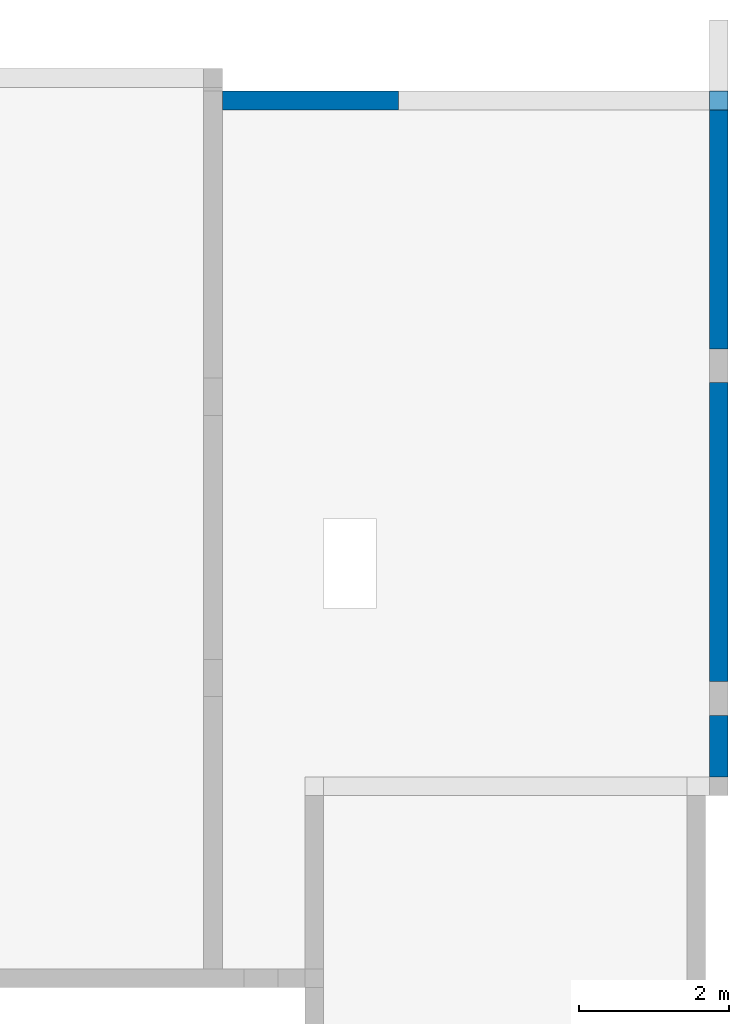
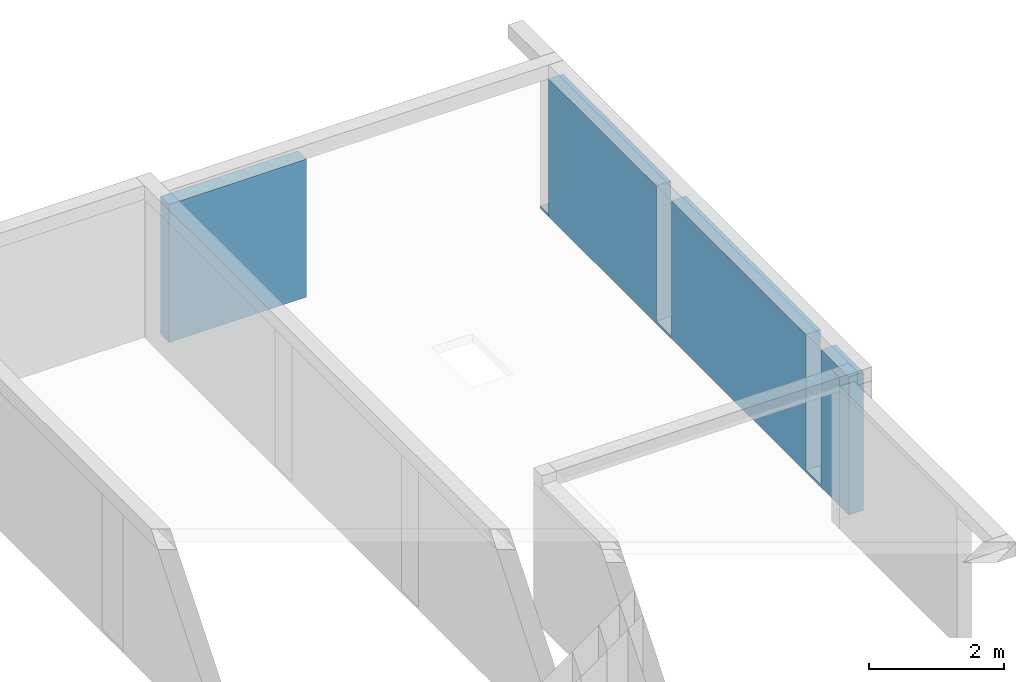
# One storey, part 2 of 2: 3 walls.
"""IFC4 building model written with IfcOpenShell, lengths in millimetres."""

from ifc_helpers import new_model, entity, si_unit, converted_unit, frame, frame_2d, origin, origin_with_axes, place, context, subcontext, project, spatial, polyline, rectangle, extrude, clip, bounded_halfspace, faceted_brep, material, layer, layer_set, layer_usage, element, save


model = new_model("IFC4")

# Units and contexts
model_context = context("Model", 3, precision=1e-05, world=origin())
plan_context = context("Plan", 3, precision=1e-05, world=origin())
body_context = subcontext(model_context, "Body", "Model", "MODEL_VIEW")
ifc_project = project(units=[si_unit("LENGTHUNIT", "METRE", prefix="MILLI"), converted_unit("PLANEANGLEUNIT", "DEGREE", entity("IfcPlaneAngleMeasure", 0.0174532925199433), si_unit("PLANEANGLEUNIT", "RADIAN"), dimensions=[0, 0, 0, 0, 0, 0, 0]), si_unit("AREAUNIT", "SQUARE_METRE"), si_unit("VOLUMEUNIT", "CUBIC_METRE")], contexts=[model_context, plan_context])

# Building, storey
building_placement = place(None, origin())
building = spatial("IfcBuilding", under=ifc_project, at=building_placement, CompositionType="ELEMENT")
storey_placement = place(building_placement, frame((0.0, 0.0, 3200.0)))
storey = spatial("IfcBuildingStorey", under=building, at=storey_placement, Name="1. Kondygnacja", CompositionType="ELEMENT", Elevation=3200.0)

# Walls
ifc_material_1 = material()
ifc_layer_1 = layer(ifc_material_1, 250.0)
ifc_layer_set_1 = layer_set([ifc_layer_1])
ifc_layer_usage_1 = layer_usage(ifc_layer_set_1, "AXIS2", "POSITIVE", 0.0)
wall_1_placement = place(storey_placement, frame((28011.87089786269, 23668.40820697431, -250.0), z_axis=(0.0, 0.0, 1.0), x_axis=(7.357709946927059e-15, -1.0, 0.0)))
element("IfcWallStandardCase", 1, at=wall_1_placement, inside=storey, material=ifc_layer_usage_1, context=body_context, shape_type="Clipping", body=[
    clip(clip(extrude(rectangle(XDim=8900.000000000002, YDim=250.0, at=frame_2d((4450.000000000001, 125.0), x_axis=(1.0, 0.0))), origin_with_axes(), (0.0, 0.0, 1.0), 2500.0), bounded_halfspace(frame((3414.999999999983, 125.0000000000003, 50.0), z_axis=(0.0, 0.0, -1.0), x_axis=(7.357709946927059e-15, 1.0, 0.0)), True, origin_with_axes(), polyline([(3639.999999999982, -1.316212557172371e-12), (3639.999999999984, 249.9999999999987), (3189.999999999984, 249.9999999999984), (3189.999999999982, -1.643221888146905e-12), (3639.999999999982, -1.316212557172371e-12)]))), bounded_halfspace(frame((7854.999999999986, 125.0000000000004, 50.0), z_axis=(0.0, 0.0, -1.0), x_axis=(7.357709946927059e-15, 1.0, 0.0)), True, origin_with_axes(), polyline([(8079.999999999985, -1.242635457703127e-12), (8079.999999999987, 249.9999999999988), (7629.999999999987, 249.9999999999984), (7629.999999999985, -1.569644788677658e-12), (8079.999999999985, -1.242635457703127e-12)]))),
])
ifc_material_2 = material()
wall_2_placement = place(storey_placement, frame((0.0, 0.0, -3200.0)))
element("IfcWall", 2, at=wall_2_placement, inside=storey, material=ifc_material_2, context=body_context, shape_type="Brep", body=[
    faceted_brep([(28261.87089786269, 23918.40820697431, 3000.0), (28261.87089786269, 23668.40820697431, 3000.0), (28011.87089786269, 23668.40820697431, 3000.0), (28011.87089786269, 23918.40820697431, 3000.0), (28261.87089786269, 23918.40820697431, 2950.0), (28011.87089786269, 23918.40820697431, 2950.0), (28011.87089786269, 23668.40820697431, 2950.0), (28261.87089786269, 23668.40820697431, 2950.0), (28011.87089786269, 23918.40820697431, 3000.0), (28011.87089786269, 23918.40820697431, 2950.0), (28261.87089786269, 23918.40820697431, 2950.0), (28261.87089786269, 23918.40820697431, 3000.0), (28011.87089786269, 23668.40820697431, 3000.0), (28011.87089786269, 23668.40820697431, 2950.0), (28011.87089786269, 23918.40820697431, 2950.0), (28011.87089786269, 23918.40820697431, 3000.0), (28261.87089786269, 23668.40820697431, 3000.0), (28261.87089786269, 23668.40820697431, 2950.0), (28011.87089786269, 23668.40820697431, 2950.0), (28011.87089786269, 23668.40820697431, 3000.0), (28261.87089786269, 23918.40820697431, 3000.0), (28261.87089786269, 23918.40820697431, 2950.0), (28261.87089786269, 23668.40820697431, 2950.0), (28261.87089786269, 23668.40820697431, 3000.0)], [[[0, 1, 2, 3]], [[4, 5, 6, 7]], [[8, 9, 10, 11]], [[12, 13, 14, 15]], [[16, 17, 18, 19]], [[20, 21, 22, 23]]], orient=[[False], [False], [False], [False], [False], [False]]),
])
ifc_material_3 = material()
ifc_layer_2 = layer(ifc_material_3, 250.0)
ifc_layer_set_2 = layer_set([ifc_layer_2])
ifc_layer_usage_2 = layer_usage(ifc_layer_set_2, "AXIS2", "POSITIVE", 0.0)
wall_3_placement = place(storey_placement, frame((21511.87089786276, 23668.40820697428, -250.0)))
element("IfcWallStandardCase", 3, at=wall_3_placement, inside=storey, material=ifc_layer_usage_2, context=body_context, shape_type="SweptSolid", body=[
    extrude(rectangle(XDim=2350.0, YDim=250.0, at=frame_2d((1175.0, 125.0), x_axis=(1.0, 0.0))), origin_with_axes(), (0.0, 0.0, 1.0), 2500.0),
])

save(model, "model.ifc")
